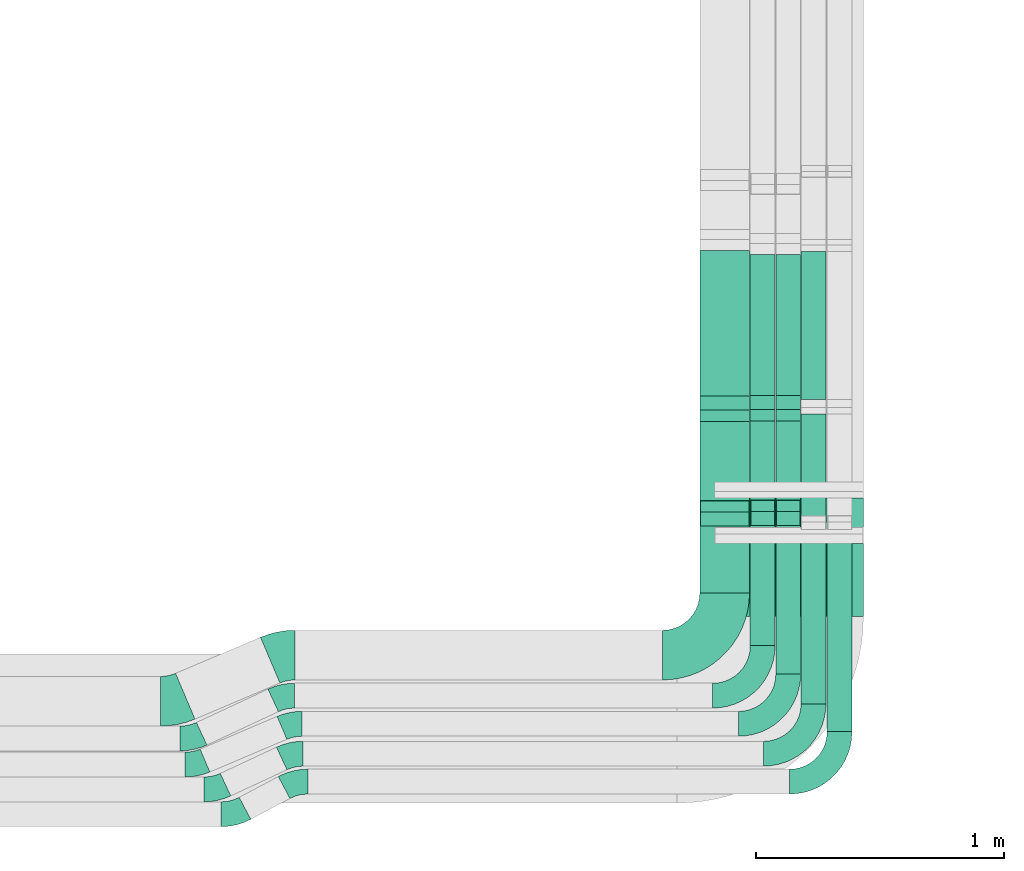
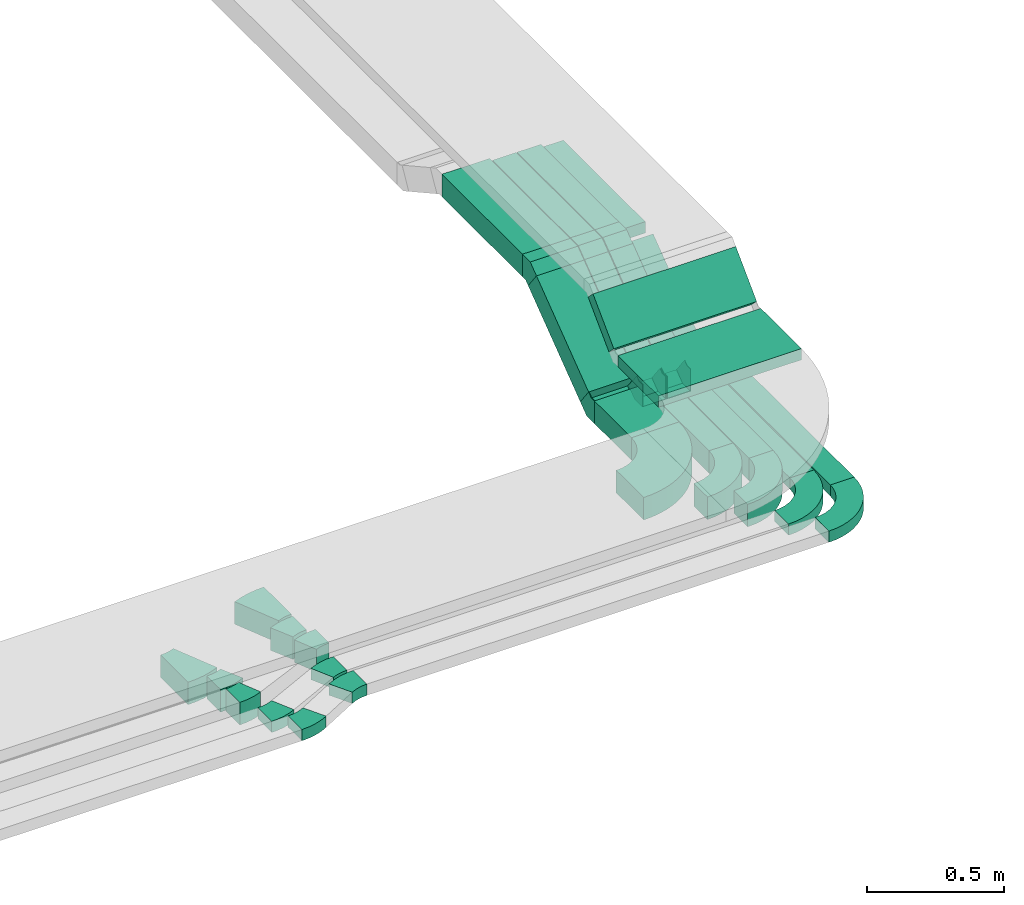
# One storey, part 16 of 28: 21 flow fittings, 15 flow segments.
"""IFC2X3 building model written with IfcOpenShell, lengths in millimetres."""

from ifc_helpers import new_model, entity, si_unit, converted_unit, derived_unit, direction, frame, frame_2d, origin, origin_2d_with_axis, place, context, subcontext, project, spatial, polyline, circle_curve, parameter, trimmed, segment, composite_curve, rectangle, outline, extrude, faceted_brep, source, transform, mapped, material, type_object, type_shapes, element, save


model = new_model("IFC2X3")

# Units and contexts
model_context = context("Model", 3, precision=0.01, world=origin(), true_north=direction((6.12303176911189e-17, 1.0)))
body_context = subcontext(model_context, "Body", "Model", "MODEL_VIEW")
ifc_project = project(units=[si_unit("LENGTHUNIT", "METRE", prefix="MILLI"), si_unit("AREAUNIT", "SQUARE_METRE"), si_unit("VOLUMEUNIT", "CUBIC_METRE"), converted_unit("PLANEANGLEUNIT", "DEGREE", entity("IfcRatioMeasure", 0.0174532925199433), si_unit("PLANEANGLEUNIT", "RADIAN"), dimensions=[0, 0, 0, 0, 0, 0, 0]), si_unit("MASSUNIT", "GRAM", prefix="KILO"), derived_unit("MASSDENSITYUNIT", [(si_unit("MASSUNIT", "GRAM", prefix="KILO"), 1), (si_unit("LENGTHUNIT", "METRE"), -3)]), derived_unit("MOMENTOFINERTIAUNIT", [(si_unit("LENGTHUNIT", "METRE"), 4)]), si_unit("TIMEUNIT", "SECOND"), si_unit("FREQUENCYUNIT", "HERTZ"), si_unit("THERMODYNAMICTEMPERATUREUNIT", "DEGREE_CELSIUS"), derived_unit("THERMALTRANSMITTANCEUNIT", [(si_unit("MASSUNIT", "GRAM", prefix="KILO"), 1), (si_unit("THERMODYNAMICTEMPERATUREUNIT", "KELVIN"), -1), (si_unit("TIMEUNIT", "SECOND"), -3)]), derived_unit("VOLUMETRICFLOWRATEUNIT", [(si_unit("LENGTHUNIT", "METRE"), 3), (si_unit("TIMEUNIT", "SECOND"), -1)]), derived_unit("MASSFLOWRATEUNIT", [(si_unit("MASSUNIT", "GRAM", prefix="KILO"), 1), (si_unit("TIMEUNIT", "SECOND"), -1)]), derived_unit("ROTATIONALFREQUENCYUNIT", [(si_unit("TIMEUNIT", "SECOND"), -1)]), si_unit("ELECTRICCURRENTUNIT", "AMPERE"), si_unit("ELECTRICVOLTAGEUNIT", "VOLT"), si_unit("POWERUNIT", "WATT"), si_unit("FORCEUNIT", "NEWTON", prefix="KILO"), si_unit("ILLUMINANCEUNIT", "LUX"), si_unit("LUMINOUSFLUXUNIT", "LUMEN"), si_unit("LUMINOUSINTENSITYUNIT", "CANDELA"), derived_unit("USERDEFINED", [(si_unit("MASSUNIT", "GRAM", prefix="KILO"), -1), (si_unit("LENGTHUNIT", "METRE"), -2), (si_unit("TIMEUNIT", "SECOND"), 3), (si_unit("LUMINOUSFLUXUNIT", "LUMEN"), 1)]), derived_unit("LINEARVELOCITYUNIT", [(si_unit("LENGTHUNIT", "METRE"), 1), (si_unit("TIMEUNIT", "SECOND"), -1)]), si_unit("PRESSUREUNIT", "PASCAL"), derived_unit("USERDEFINED", [(si_unit("LENGTHUNIT", "METRE"), -2), (si_unit("MASSUNIT", "GRAM", prefix="KILO"), 1), (si_unit("TIMEUNIT", "SECOND"), -2)]), derived_unit("LINEARFORCEUNIT", [(si_unit("MASSUNIT", "GRAM", prefix="KILO"), 1), (si_unit("LENGTHUNIT", "METRE"), 1), (si_unit("TIMEUNIT", "SECOND"), -2), (si_unit("LENGTHUNIT", "METRE"), -1)]), derived_unit("PLANARFORCEUNIT", [(si_unit("MASSUNIT", "GRAM", prefix="KILO"), 1), (si_unit("LENGTHUNIT", "METRE"), 1), (si_unit("TIMEUNIT", "SECOND"), -2), (si_unit("LENGTHUNIT", "METRE"), -2)])], contexts=[model_context])

# Site, building, storey
site_placement = place(None, origin())
site = spatial("IfcSite", under=ifc_project, at=site_placement, CompositionType="ELEMENT")
building_placement = place(site_placement, origin())
building = spatial("IfcBuilding", under=site, at=building_placement, CompositionType="ELEMENT")
storey_placement = place(building_placement, frame((0.0, 0.0, 4200.0)))
storey = spatial("IfcBuildingStorey", under=building, at=storey_placement, CompositionType="ELEMENT", Elevation=4200.0)

# Flow segments
cable_carrier_segment_type = type_object("IfcCableCarrierSegmentType", PredefinedType="CABLETRAYSEGMENT")
flow_segment_1_placement = place(storey_placement, frame((38752.82, 1188.25, 2836.0)))
element("IfcFlowSegment", 1, at=flow_segment_1_placement, inside=storey, type_object=cable_carrier_segment_type, context=body_context, shape_type="SweptSolid", body=[
    extrude(rectangle(XDim=269.298544442396, YDim=199.999999999998, at=origin_2d_with_axis()), frame((100.0, 134.65, 0.0), z_axis=(0.0, 0.0, 1.0), x_axis=(0.0, 1.0, 0.0)), (0.0, 0.0, 1.0), 99.9999999999989),
])
flow_segment_2_placement = place(storey_placement, frame((38752.82, 1499.65, 2870.22)))
element("IfcFlowSegment", 2, at=flow_segment_2_placement, inside=storey, type_object=cable_carrier_segment_type, context=body_context, shape_type="SweptSolid", body=[
    extrude(rectangle(XDim=99.9999999999993, YDim=474.734982904556, at=frame_2d((0.0, 0.0), x_axis=(0.0, 1.0))), frame((0.0, 219.66, 182.78), z_axis=(1.0, 0.0, 0.0), x_axis=(0.0, 0.798635510047289, 0.601815023152054)), (0.0, 0.0, 1.0), 199.999999999998),
])
flow_segment_3_placement = place(storey_placement, frame((38752.82, 1981.06, 3170.01)))
element("IfcFlowSegment", 3, at=flow_segment_3_placement, inside=storey, type_object=cable_carrier_segment_type, context=body_context, shape_type="SweptSolid", body=[
    extrude(rectangle(XDim=585.704970645481, YDim=199.999999999998, at=origin_2d_with_axis()), frame((100.0, 292.85, 0.0), z_axis=(0.0, 0.0, 1.0), x_axis=(0.0, -1.0, 0.0)), (0.0, 0.0, 1.0), 99.9999999999989),
])
flow_segment_4_placement = place(storey_placement, frame((38955.52, 1982.94, 3170.44)))
element("IfcFlowSegment", 4, at=flow_segment_4_placement, inside=storey, type_object=cable_carrier_segment_type, context=body_context, shape_type="SweptSolid", body=[
    extrude(rectangle(XDim=567.712645094914, YDim=100.000000000003, at=origin_2d_with_axis()), frame((50.0, 283.86, 0.0), z_axis=(0.0, 0.0, 1.0), x_axis=(0.0, -1.0, 0.0)), (0.0, 0.0, 1.0), 99.9999999999989),
])
flow_segment_5_placement = place(storey_placement, frame((38955.52, 1500.95, 2870.22)))
element("IfcFlowSegment", 5, at=flow_segment_5_placement, inside=storey, type_object=cable_carrier_segment_type, context=body_context, shape_type="SweptSolid", body=[
    extrude(rectangle(XDim=99.9999999999994, YDim=475.458707317659, at=frame_2d((0.0, 0.0), x_axis=(0.0, 1.0))), frame((0.0, 219.95, 183.0), z_axis=(1.0, 0.0, 0.0), x_axis=(0.0, -0.798635510047221, -0.601815023152144)), (0.0, 0.0, 1.0), 100.000000000003),
])
flow_segment_6_placement = place(storey_placement, frame((38955.52, 975.16, 2836.0)))
element("IfcFlowSegment", 6, at=flow_segment_6_placement, inside=storey, type_object=cable_carrier_segment_type, context=body_context, shape_type="SweptSolid", body=[
    extrude(rectangle(XDim=483.697987779562, YDim=100.000000000003, at=origin_2d_with_axis()), frame((50.0, 241.85, 0.0), z_axis=(0.0, 0.0, 1.0), x_axis=(0.0, 1.0, 0.0)), (0.0, 0.0, 1.0), 100.0),
])
flow_segment_7_placement = place(storey_placement, frame((39058.82, 861.76, 2836.0)))
element("IfcFlowSegment", 7, at=flow_segment_7_placement, inside=storey, type_object=cable_carrier_segment_type, context=body_context, shape_type="SweptSolid", body=[
    extrude(rectangle(XDim=597.090583745162, YDim=99.9999999999946, at=origin_2d_with_axis()), frame((50.0, 298.55, 0.0), z_axis=(0.0, 0.0, 1.0), x_axis=(0.0, 1.0, 0.0)), (0.0, 0.0, 1.0), 99.9999999999989),
])
flow_segment_8_placement = place(storey_placement, frame((39058.82, 1982.94, 3170.44)))
element("IfcFlowSegment", 8, at=flow_segment_8_placement, inside=storey, type_object=cable_carrier_segment_type, context=body_context, shape_type="SweptSolid", body=[
    extrude(rectangle(XDim=567.712645094897, YDim=99.9999999999946, at=origin_2d_with_axis()), frame((50.0, 283.86, 0.0), z_axis=(0.0, 0.0, 1.0), x_axis=(0.0, -1.0, 0.0)), (0.0, 0.0, 1.0), 99.9999999999989),
])
flow_segment_9_placement = place(storey_placement, frame((39058.82, 1500.95, 2870.22)))
element("IfcFlowSegment", 9, at=flow_segment_9_placement, inside=storey, type_object=cable_carrier_segment_type, context=body_context, shape_type="SweptSolid", body=[
    extrude(rectangle(XDim=100.000000000001, YDim=99.9999999999946, at=origin_2d_with_axis()), frame((50.0, 30.09, 39.93), z_axis=(0.0, 0.798635510047284, 0.60181502315206), x_axis=(0.0, -0.60181502315206, 0.798635510047284)), (0.0, 0.0, 1.0), 475.45870731771),
])
flow_segment_10_placement = place(storey_placement, frame((39265.32, 629.11, 2836.0)))
element("IfcFlowSegment", 10, at=flow_segment_10_placement, inside=storey, type_object=cable_carrier_segment_type, context=body_context, shape_type="SweptSolid", body=[
    extrude(rectangle(XDim=813.299265565232, YDim=99.9999999999946, at=origin_2d_with_axis()), frame((50.0, 406.65, 0.0), z_axis=(0.0, 0.0, 1.0), x_axis=(0.0, 1.0, 0.0)), (0.0, 0.0, 1.0), 49.9999999999995),
])
flow_segment_11_placement = place(storey_placement, frame((39160.32, 1966.21, 3195.44)))
element("IfcFlowSegment", 11, at=flow_segment_11_placement, inside=storey, type_object=cable_carrier_segment_type, context=body_context, shape_type="SweptSolid", body=[
    extrude(rectangle(XDim=597.373290287799, YDim=99.9999999999946, at=origin_2d_with_axis()), frame((50.0, 298.69, 0.0), z_axis=(0.0, 0.0, 1.0), x_axis=(0.0, -1.0, 0.0)), (0.0, 0.0, 1.0), 49.9999999999995),
])
flow_segment_12_placement = place(storey_placement, frame((39160.32, 1469.46, 2855.12)))
element("IfcFlowSegment", 12, at=flow_segment_12_placement, inside=storey, type_object=cable_carrier_segment_type, context=body_context, shape_type="SweptSolid", body=[
    extrude(rectangle(XDim=49.9999999999999, YDim=550.459242796006, at=frame_2d((0.0, 0.0), x_axis=(0.0, 1.0))), frame((0.0, 234.85, 185.6), z_axis=(1.0, 0.0, 0.0), x_axis=(0.0, -0.798635510047261, -0.60181502315209)), (0.0, 0.0, 1.0), 99.9999999999945),
])
flow_segment_13_placement = place(storey_placement, frame((39160.32, 741.35, 2836.0)))
element("IfcFlowSegment", 13, at=flow_segment_13_placement, inside=storey, type_object=cable_carrier_segment_type, context=body_context, shape_type="SweptSolid", body=[
    extrude(rectangle(XDim=701.061094153478, YDim=99.9999999999946, at=origin_2d_with_axis()), frame((50.0, 350.53, 0.0), z_axis=(0.0, 0.0, 1.0), x_axis=(0.0, 1.0, 0.0)), (0.0, 0.0, 1.0), 49.9999999999995),
])
flow_segment_14_placement = place(storey_placement, frame((38811.38, 1417.48, 3135.82)))
element("IfcFlowSegment", 14, at=flow_segment_14_placement, inside=storey, type_object=cable_carrier_segment_type, context=body_context, shape_type="SweptSolid", body=[
    extrude(rectangle(XDim=49.9999999999995, YDim=214.759813245738, at=frame_2d((0.0, 0.0), x_axis=(0.0, 1.0))), frame((0.0, 93.61, 93.61), z_axis=(1.0, 0.0, 0.0), x_axis=(0.0, -0.707106781186602, -0.707106781186493)), (0.0, 0.0, 1.0), 600.000000000002),
])
flow_segment_15_placement = place(storey_placement, frame((38811.38, 1092.66, 3108.85)))
element("IfcFlowSegment", 15, at=flow_segment_15_placement, inside=storey, type_object=cable_carrier_segment_type, context=body_context, shape_type="SweptSolid", body=[
    extrude(rectangle(XDim=295.070811915794, YDim=600.000000000002, at=origin_2d_with_axis()), frame((300.0, 147.54, 0.0), z_axis=(0.0, 0.0, 1.0), x_axis=(0.0, 1.0, 0.0)), (0.0, 0.0, 1.0), 49.9999999999995),
])

# Flow fittings
ifc_material = material()
cable_carrier_fitting_type_1 = type_object("IfcCableCarrierFittingType", PredefinedType="NOTDEFINED", material=ifc_material)
shared_shape_1 = source(origin(), body_context, "Body", "Brep", [
    faceted_brep([(-40.13, -50.0, 100.0), (-40.13, 50.0, 100.0), (-40.13, 50.0, 97.46), (-40.13, -47.46, 97.46), (-40.13, -47.46, -97.46), (-40.13, 50.0, -97.46), (-40.13, 50.0, -100.0), (-40.13, -50.0, -100.0), (62.14, -15.78, 100.0), (62.14, -15.78, -100.0), (1.96, 64.08, -100.0), (1.96, 64.08, -97.46), (60.61, -13.75, -97.46), (60.61, -13.75, 97.46), (1.96, 64.08, 97.46), (1.96, 64.08, 100.0), (16.73, -50.0, 100.0), (-16.73, 50.0, 100.0), (-16.73, 50.0, 97.46), (15.88, -47.46, 97.46), (15.88, -47.46, -97.46), (-16.73, 50.0, -97.46), (-16.73, 50.0, -100.0), (16.73, -50.0, -100.0)], [[[0, 1, 2, 3, 4, 5, 6, 7]], [[8, 9, 10, 11, 12, 13, 14, 15]], [[1, 0, 16, 8, 15, 17]], [[2, 1, 17, 18]], [[3, 2, 18, 14, 13, 19]], [[4, 3, 19, 20]], [[5, 4, 20, 12, 11, 21]], [[6, 5, 21, 22]], [[7, 6, 22, 10, 9, 23]], [[0, 7, 23, 16]], [[18, 17, 15, 14]], [[20, 19, 13, 12]], [[22, 21, 11, 10]], [[16, 23, 9, 8]]]),
])
type_shapes(cable_carrier_fitting_type_1, [shared_shape_1])
for number, where, z_axis, x_axis in (
    (16, (38852.82, 1497.69, 2886.0), (1.0, 0.0, 0.0), (0.0, 1.0, 0.0)),
    (17, (38852.82, 1940.93, 3220.01), (-1.0, 0.0, 0.0), (0.0, 0.798635510047237, 0.601815023152122)),
):
    element("IfcFlowFitting", number, at=place(storey_placement, frame(where, z_axis=z_axis, x_axis=x_axis)), inside=storey, type_object=cable_carrier_fitting_type_1, material=ifc_material, context=body_context, shape_type="MappedRepresentation", body=[
        mapped(shared_shape_1, transform((0.0, 0.0, 0.0), scale=1.0)),
    ])
cable_carrier_fitting_type_2 = type_object("IfcCableCarrierFittingType", PredefinedType="NOTDEFINED", material=ifc_material)
shared_shape_2 = source(origin(), body_context, "Body", "Brep", [
    faceted_brep([(-40.13, -50.0, 50.0), (-40.13, 50.0, 50.0), (-40.13, 50.0, 47.46), (-40.13, -47.46, 47.46), (-40.13, -47.46, -47.46), (-40.13, 50.0, -47.46), (-40.13, 50.0, -50.0), (-40.13, -50.0, -50.0), (62.14, -15.78, 50.0), (62.14, -15.78, -50.0), (1.96, 64.08, -50.0), (1.96, 64.08, -47.46), (60.61, -13.75, -47.46), (60.61, -13.75, 47.46), (1.96, 64.08, 47.46), (1.96, 64.08, 50.0), (16.73, -50.0, 50.0), (-16.73, 50.0, 50.0), (-16.73, 50.0, 47.46), (15.88, -47.46, 47.46), (15.88, -47.46, -47.46), (-16.73, 50.0, -47.46), (-16.73, 50.0, -50.0), (16.73, -50.0, -50.0)], [[[0, 1, 2, 3, 4, 5, 6, 7]], [[8, 9, 10, 11, 12, 13, 14, 15]], [[1, 0, 16, 8, 15, 17]], [[2, 1, 17, 18]], [[3, 2, 18, 14, 13, 19]], [[4, 3, 19, 20]], [[5, 4, 20, 12, 11, 21]], [[6, 5, 21, 22]], [[7, 6, 22, 10, 9, 23]], [[0, 7, 23, 16]], [[18, 17, 15, 14]], [[20, 19, 13, 12]], [[22, 21, 11, 10]], [[16, 23, 9, 8]]]),
])
type_shapes(cable_carrier_fitting_type_2, [shared_shape_2])
for number, where, z_axis, x_axis in (
    (18, (39005.52, 1942.81, 3220.44), (1.0, 0.0, 0.0), (0.0, -1.0, 0.0)),
    (19, (39005.52, 1498.99, 2886.0), (1.0, 0.0, 0.0), (0.0, 1.0, 0.0)),
    (20, (39108.82, 1942.81, 3220.44), (1.0, 0.0, 0.0), (0.0, -1.0, 0.0)),
    (21, (39108.82, 1498.99, 2886.0), (-1.0, 0.0, 0.0), (0.0, -0.79863551004726, -0.601815023152092)),
):
    element("IfcFlowFitting", number, at=place(storey_placement, frame(where, z_axis=z_axis, x_axis=x_axis)), inside=storey, type_object=cable_carrier_fitting_type_2, material=ifc_material, context=body_context, shape_type="MappedRepresentation", body=[
        mapped(shared_shape_2, transform((0.0, 0.0, 0.0), scale=1.0)),
    ])
cable_carrier_fitting_type_3 = type_object("IfcCableCarrierFittingType", Name="470_DKC_S5_Variable Angle Elbow 0-45:-", PredefinedType="NOTDEFINED", material=ifc_material)
shared_shape_3 = source(origin(), body_context, "Body", "SweptSolid", [
    extrude(outline(composite_curve([segment(polyline([(-125.75, -225.25), (-124.75, -225.25)]), True, "CONTINUOUS"), segment(trimmed(circle_curve(frame_2d((-124.75, 124.75), x_axis=(0.0, -1.0)), 350.0), [parameter(0.0)], [parameter(90.0000000000001)], True, "PARAMETER"), True, "CONTINUOUS"), segment(polyline([(225.25, 124.75), (225.25, 125.75)]), True, "CONTINUOUS"), segment(polyline([(225.25, 125.75), (25.25, 125.75)]), True, "CONTINUOUS"), segment(polyline([(25.25, 125.75), (25.25, 124.75)]), True, "CONTINUOUS"), segment(trimmed(circle_curve(frame_2d((-124.75, 124.75), x_axis=(0.0, -1.0)), 150.0), [parameter(0.0)], [parameter(90.0000000000001)], True, "PARAMETER"), False, "CONTINUOUS"), segment(polyline([(-124.75, -25.25), (-125.75, -25.25)]), True, "CONTINUOUS"), segment(polyline([(-125.75, -25.25), (-125.75, -225.25)]), True, "CONTINUOUS")], self_intersect=False)), frame((-125.25, 125.25, -50.0)), (0.0, 0.0, 1.0), 100.0),
])
type_shapes(cable_carrier_fitting_type_3, [shared_shape_3])
flow_fitting_1_placement = place(storey_placement, frame((38852.82, 937.25, 2886.0)))
element("IfcFlowFitting", 22, at=flow_fitting_1_placement, inside=storey, type_object=cable_carrier_fitting_type_3, material=ifc_material, Name="470_DKC_S5_Variable Angle Elbow 0-45:-", ObjectType="470_DKC_S5_Variable Angle Elbow 0-45:-", context=body_context, shape_type="MappedRepresentation", body=[
    mapped(shared_shape_3, transform((0.0, 0.0, 0.0), scale=1.0)),
])
cable_carrier_fitting_type_4 = type_object("IfcCableCarrierFittingType", Name="470_DKC_S5_Variable Angle Elbow 0-45:-", PredefinedType="NOTDEFINED", material=ifc_material)
shared_shape_4 = source(origin(), body_context, "Body", "SweptSolid", [
    extrude(outline(composite_curve([segment(polyline([(-100.75, -150.25), (-99.75, -150.25)]), True, "CONTINUOUS"), segment(trimmed(circle_curve(frame_2d((-99.75, 99.75), x_axis=(0.0, -1.0)), 250.0), [parameter(0.0)], [parameter(90.0000000000001)], True, "PARAMETER"), True, "CONTINUOUS"), segment(polyline([(150.25, 99.75), (150.25, 100.75)]), True, "CONTINUOUS"), segment(polyline([(150.25, 100.75), (50.25, 100.75)]), True, "CONTINUOUS"), segment(polyline([(50.25, 100.75), (50.25, 99.75)]), True, "CONTINUOUS"), segment(trimmed(circle_curve(frame_2d((-99.75, 99.75), x_axis=(0.0, -1.0)), 150.0), [parameter(0.0)], [parameter(90.0000000000001)], True, "PARAMETER"), False, "CONTINUOUS"), segment(polyline([(-99.75, -50.25), (-100.75, -50.25)]), True, "CONTINUOUS"), segment(polyline([(-100.75, -50.25), (-100.75, -150.25)]), True, "CONTINUOUS")], self_intersect=False)), frame((-100.25, 100.25, -25.0)), (0.0, 0.0, 1.0), 49.9999999999997),
])
type_shapes(cable_carrier_fitting_type_4, [shared_shape_4])
for number, where, name in (
    (23, (39210.32, 540.35, 2861.0), "470_DKC_S5_Variable Angle Elbow 0-45:-"),
    (24, (39315.32, 428.11, 2861.0), "470_DKC_S5_Variable Angle Elbow 0-45:-"),
):
    element("IfcFlowFitting", number, at=place(storey_placement, frame(where)), inside=storey, type_object=cable_carrier_fitting_type_4, material=ifc_material, Name=name, ObjectType="470_DKC_S5_Variable Angle Elbow 0-45:-", context=body_context, shape_type="MappedRepresentation", body=[
        mapped(shared_shape_4, transform((0.0, 0.0, 0.0), scale=1.0)),
    ])
cable_carrier_fitting_type_5 = type_object("IfcCableCarrierFittingType", Name="470_DKC_S5_Variable Angle Elbow 0-45:-", PredefinedType="NOTDEFINED", material=ifc_material)
shared_shape_5 = source(origin(), body_context, "Body", "SweptSolid", [
    extrude(outline(composite_curve([segment(polyline([(-100.75, -150.25), (-99.75, -150.25)]), True, "CONTINUOUS"), segment(trimmed(circle_curve(frame_2d((-99.75, 99.75), x_axis=(0.0, -1.0)), 250.0), [parameter(0.0)], [parameter(90.0000000000001)], True, "PARAMETER"), True, "CONTINUOUS"), segment(polyline([(150.25, 99.75), (150.25, 100.75)]), True, "CONTINUOUS"), segment(polyline([(150.25, 100.75), (50.25, 100.75)]), True, "CONTINUOUS"), segment(polyline([(50.25, 100.75), (50.25, 99.75)]), True, "CONTINUOUS"), segment(trimmed(circle_curve(frame_2d((-99.75, 99.75), x_axis=(0.0, -1.0)), 150.0), [parameter(0.0)], [parameter(90.0000000000001)], True, "PARAMETER"), False, "CONTINUOUS"), segment(polyline([(-99.75, -50.25), (-100.75, -50.25)]), True, "CONTINUOUS"), segment(polyline([(-100.75, -50.25), (-100.75, -150.25)]), True, "CONTINUOUS")], self_intersect=False)), frame((-100.25, 100.25, -50.0)), (0.0, 0.0, 1.0), 100.0),
])
type_shapes(cable_carrier_fitting_type_5, [shared_shape_5])
for number, where, name in (
    (25, (39005.52, 774.16, 2886.0), "470_DKC_S5_Variable Angle Elbow 0-45:-"),
    (26, (39108.82, 660.76, 2886.0), "470_DKC_S5_Variable Angle Elbow 0-45:-"),
):
    element("IfcFlowFitting", number, at=place(storey_placement, frame(where)), inside=storey, type_object=cable_carrier_fitting_type_5, material=ifc_material, Name=name, ObjectType="470_DKC_S5_Variable Angle Elbow 0-45:-", context=body_context, shape_type="MappedRepresentation", body=[
        mapped(shared_shape_5, transform((0.0, 0.0, 0.0), scale=1.0)),
    ])
cable_carrier_fitting_type_6 = type_object("IfcCableCarrierFittingType", Name="470_DKC_S5_Variable Angle Elbow 0-45:-", PredefinedType="NOTDEFINED", material=ifc_material)
shared_shape_6 = source(origin(), body_context, "Body", "SweptSolid", [
    extrude(outline(composite_curve([segment(polyline([(-43.24, -59.47), (-42.24, -59.47)]), True, "CONTINUOUS"), segment(trimmed(circle_curve(frame_2d((-42.24, 190.53), x_axis=(0.0, -1.0)), 250.0), [parameter(0.0)], [parameter(24.9999999999996)], True, "PARAMETER"), True, "CONTINUOUS"), segment(polyline([(63.42, -36.05), (64.32, -35.63)]), True, "CONTINUOUS"), segment(polyline([(64.32, -35.63), (22.06, 55.0)]), True, "CONTINUOUS"), segment(polyline([(22.06, 55.0), (21.15, 54.58)]), True, "CONTINUOUS"), segment(trimmed(circle_curve(frame_2d((-42.24, 190.53), x_axis=(0.0, -1.0)), 150.0), [parameter(0.0)], [parameter(24.9999999999996)], True, "PARAMETER"), False, "CONTINUOUS"), segment(polyline([(-42.24, 40.53), (-43.24, 40.53)]), True, "CONTINUOUS"), segment(polyline([(-43.24, 40.53), (-43.24, -59.47)]), True, "CONTINUOUS")], self_intersect=False)), frame((-2.1, 9.47, -25.0)), (0.0, 0.0, 1.0), 50.0),
])
type_shapes(cable_carrier_fitting_type_6, [shared_shape_6])
flow_fitting_2_placement = place(storey_placement, frame((36801.82, 396.66, 2861.0)))
element("IfcFlowFitting", 27, at=flow_fitting_2_placement, inside=storey, type_object=cable_carrier_fitting_type_6, material=ifc_material, Name="470_DKC_S5_Variable Angle Elbow 0-45:-", ObjectType="470_DKC_S5_Variable Angle Elbow 0-45:-", context=body_context, shape_type="MappedRepresentation", body=[
    mapped(shared_shape_6, transform((0.0, 0.0, 0.0), scale=1.0)),
])
flow_fitting_3_placement = place(storey_placement, frame((37109.97, 540.35, 2861.0), z_axis=(0.0, 0.0, 1.0), x_axis=(-1.0, 0.0, 0.0)))
element("IfcFlowFitting", 28, at=flow_fitting_3_placement, inside=storey, type_object=cable_carrier_fitting_type_6, material=ifc_material, Name="470_DKC_S5_Variable Angle Elbow 0-45:-", ObjectType="470_DKC_S5_Variable Angle Elbow 0-45:-", context=body_context, shape_type="MappedRepresentation", body=[
    mapped(shared_shape_6, transform((0.0, 0.0, 0.0), scale=1.0)),
])
cable_carrier_fitting_type_7 = type_object("IfcCableCarrierFittingType", Name="470_DKC_S5_Variable Angle Elbow 0-45:-", PredefinedType="NOTDEFINED", material=ifc_material)
shared_shape_7 = source(origin(), body_context, "Body", "SweptSolid", [
    extrude(outline(composite_curve([segment(polyline([(-47.92, -61.82), (-46.92, -61.82)]), True, "CONTINUOUS"), segment(trimmed(circle_curve(frame_2d((-46.92, 188.18), x_axis=(0.0, -1.0)), 250.0), [parameter(0.0)], [parameter(27.9999999999998)], True, "PARAMETER"), True, "CONTINUOUS"), segment(polyline([(70.45, -32.56), (71.33, -32.09)]), True, "CONTINUOUS"), segment(polyline([(71.33, -32.09), (24.39, 56.2)]), True, "CONTINUOUS"), segment(polyline([(24.39, 56.2), (23.5, 55.74)]), True, "CONTINUOUS"), segment(trimmed(circle_curve(frame_2d((-46.92, 188.18), x_axis=(0.0, -1.0)), 150.0), [parameter(0.0)], [parameter(27.9999999999998)], True, "PARAMETER"), False, "CONTINUOUS"), segment(polyline([(-46.92, 38.18), (-47.92, 38.18)]), True, "CONTINUOUS"), segment(polyline([(-47.92, 38.18), (-47.92, -61.82)]), True, "CONTINUOUS")], self_intersect=False)), frame((-2.95, 11.82, -25.0)), (0.0, 0.0, 1.0), 50.0),
])
type_shapes(cable_carrier_fitting_type_7, [shared_shape_7])
flow_fitting_4_placement = place(storey_placement, frame((36876.32, 296.66, 2861.0)))
element("IfcFlowFitting", 29, at=flow_fitting_4_placement, inside=storey, type_object=cable_carrier_fitting_type_7, material=ifc_material, Name="470_DKC_S5_Variable Angle Elbow 0-45:-", ObjectType="470_DKC_S5_Variable Angle Elbow 0-45:-", context=body_context, shape_type="MappedRepresentation", body=[
    mapped(shared_shape_7, transform((0.0, 0.0, 0.0), scale=1.0)),
])
flow_fitting_5_placement = place(storey_placement, frame((37123.54, 428.11, 2861.0), z_axis=(0.0, 0.0, 1.0), x_axis=(-1.0, 0.0, 0.0)))
element("IfcFlowFitting", 30, at=flow_fitting_5_placement, inside=storey, type_object=cable_carrier_fitting_type_7, material=ifc_material, Name="470_DKC_S5_Variable Angle Elbow 0-45:-", ObjectType="470_DKC_S5_Variable Angle Elbow 0-45:-", context=body_context, shape_type="MappedRepresentation", body=[
    mapped(shared_shape_7, transform((0.0, 0.0, 0.0), scale=1.0)),
])
cable_carrier_fitting_type_8 = type_object("IfcCableCarrierFittingType", Name="470_DKC_S5_Variable Angle Elbow 0-45:-", PredefinedType="NOTDEFINED", material=ifc_material)
shared_shape_8 = source(origin(), body_context, "Body", "SweptSolid", [
    extrude(outline(composite_curve([segment(polyline([(-40.05, -58.05), (-39.05, -58.05)]), True, "CONTINUOUS"), segment(trimmed(circle_curve(frame_2d((-39.05, 191.95), x_axis=(0.0, -1.0)), 250.0), [parameter(0.0)], [parameter(23.0)], True, "PARAMETER"), True, "CONTINUOUS"), segment(polyline([(58.63, -38.17), (59.55, -37.78)]), True, "CONTINUOUS"), segment(polyline([(59.55, -37.78), (20.48, 54.27)]), True, "CONTINUOUS"), segment(polyline([(20.48, 54.27), (19.56, 53.88)]), True, "CONTINUOUS"), segment(trimmed(circle_curve(frame_2d((-39.05, 191.95), x_axis=(0.0, -1.0)), 150.0), [parameter(0.0)], [parameter(23.0)], True, "PARAMETER"), False, "CONTINUOUS"), segment(polyline([(-39.05, 41.95), (-40.05, 41.95)]), True, "CONTINUOUS"), segment(polyline([(-40.05, 41.95), (-40.05, -58.05)]), True, "CONTINUOUS")], self_intersect=False)), frame((-1.64, 8.05, -50.0)), (0.0, 0.0, 1.0), 100.0),
])
type_shapes(cable_carrier_fitting_type_8, [shared_shape_8])
flow_fitting_6_placement = place(storey_placement, frame((36721.82, 496.66, 2886.0)))
element("IfcFlowFitting", 31, at=flow_fitting_6_placement, inside=storey, type_object=cable_carrier_fitting_type_8, material=ifc_material, Name="470_DKC_S5_Variable Angle Elbow 0-45:-", ObjectType="470_DKC_S5_Variable Angle Elbow 0-45:-", context=body_context, shape_type="MappedRepresentation", body=[
    mapped(shared_shape_8, transform((0.0, 0.0, 0.0), scale=1.0)),
])
flow_fitting_7_placement = place(storey_placement, frame((37108.43, 660.76, 2886.0), z_axis=(0.0, 0.0, 1.0), x_axis=(-1.0, 0.0, 0.0)))
element("IfcFlowFitting", 32, at=flow_fitting_7_placement, inside=storey, type_object=cable_carrier_fitting_type_8, material=ifc_material, Name="470_DKC_S5_Variable Angle Elbow 0-45:-", ObjectType="470_DKC_S5_Variable Angle Elbow 0-45:-", context=body_context, shape_type="MappedRepresentation", body=[
    mapped(shared_shape_8, transform((0.0, 0.0, 0.0), scale=1.0)),
])
cable_carrier_fitting_type_9 = type_object("IfcCableCarrierFittingType", Name="470_DKC_S5_Variable Angle Elbow 0-45:-", PredefinedType="NOTDEFINED", material=ifc_material)
shared_shape_9 = source(origin(), body_context, "Body", "SweptSolid", [
    extrude(outline(composite_curve([segment(polyline([(-43.24, -59.47), (-42.24, -59.47)]), True, "CONTINUOUS"), segment(trimmed(circle_curve(frame_2d((-42.24, 190.53), x_axis=(0.0, -1.0)), 250.0), [parameter(0.0)], [parameter(25.0000000000054)], True, "PARAMETER"), True, "CONTINUOUS"), segment(polyline([(63.42, -36.05), (64.32, -35.63)]), True, "CONTINUOUS"), segment(polyline([(64.32, -35.63), (22.06, 55.0)]), True, "CONTINUOUS"), segment(polyline([(22.06, 55.0), (21.15, 54.58)]), True, "CONTINUOUS"), segment(trimmed(circle_curve(frame_2d((-42.24, 190.53), x_axis=(0.0, -1.0)), 150.0), [parameter(0.0)], [parameter(25.0000000000054)], True, "PARAMETER"), False, "CONTINUOUS"), segment(polyline([(-42.24, 40.53), (-43.24, 40.53)]), True, "CONTINUOUS"), segment(polyline([(-43.24, 40.53), (-43.24, -59.47)]), True, "CONTINUOUS")], self_intersect=False)), frame((-2.1, 9.47, -50.0)), (0.0, 0.0, 1.0), 100.0),
])
type_shapes(cable_carrier_fitting_type_9, [shared_shape_9])
flow_fitting_8_placement = place(storey_placement, frame((36705.74, 601.66, 2886.0)))
element("IfcFlowFitting", 33, at=flow_fitting_8_placement, inside=storey, type_object=cable_carrier_fitting_type_9, material=ifc_material, Name="470_DKC_S5_Variable Angle Elbow 0-45:-", ObjectType="470_DKC_S5_Variable Angle Elbow 0-45:-", context=body_context, shape_type="MappedRepresentation", body=[
    mapped(shared_shape_9, transform((0.0, 0.0, 0.0), scale=1.0)),
])
flow_fitting_9_placement = place(storey_placement, frame((37075.67, 774.16, 2886.0), z_axis=(0.0, 0.0, 1.0), x_axis=(-1.0, 0.0, 0.0)))
element("IfcFlowFitting", 34, at=flow_fitting_9_placement, inside=storey, type_object=cable_carrier_fitting_type_9, material=ifc_material, Name="470_DKC_S5_Variable Angle Elbow 0-45:-", ObjectType="470_DKC_S5_Variable Angle Elbow 0-45:-", context=body_context, shape_type="MappedRepresentation", body=[
    mapped(shared_shape_9, transform((0.0, 0.0, 0.0), scale=1.0)),
])
cable_carrier_fitting_type_10 = type_object("IfcCableCarrierFittingType", Name="470_DKC_S5_Variable Angle Elbow 0-45:-", PredefinedType="NOTDEFINED", material=ifc_material)
shared_shape_10 = source(origin(), body_context, "Body", "SweptSolid", [
    extrude(outline(composite_curve([segment(polyline([(-49.82, -110.03), (-48.82, -110.03)]), True, "CONTINUOUS"), segment(trimmed(circle_curve(frame_2d((-48.82, 239.97), x_axis=(0.0, -1.0)), 350.0), [parameter(0.0)], [parameter(23.000000000004)], True, "PARAMETER"), True, "CONTINUOUS"), segment(polyline([(87.93, -82.21), (88.85, -81.82)]), True, "CONTINUOUS"), segment(polyline([(88.85, -81.82), (10.71, 102.28)]), True, "CONTINUOUS"), segment(polyline([(10.71, 102.28), (9.79, 101.89)]), True, "CONTINUOUS"), segment(trimmed(circle_curve(frame_2d((-48.82, 239.97), x_axis=(0.0, -1.0)), 150.0), [parameter(0.0)], [parameter(23.000000000004)], True, "PARAMETER"), False, "CONTINUOUS"), segment(polyline([(-48.82, 89.97), (-49.82, 89.97)]), True, "CONTINUOUS"), segment(polyline([(-49.82, 89.97), (-49.82, -110.03)]), True, "CONTINUOUS")], self_intersect=False)), frame((-2.04, 10.03, -50.0)), (0.0, 0.0, 1.0), 100.0),
])
type_shapes(cable_carrier_fitting_type_10, [shared_shape_10])
flow_fitting_10_placement = place(storey_placement, frame((36633.09, 751.66, 2886.0)))
element("IfcFlowFitting", 35, at=flow_fitting_10_placement, inside=storey, type_object=cable_carrier_fitting_type_10, material=ifc_material, Name="470_DKC_S5_Variable Angle Elbow 0-45:-", ObjectType="470_DKC_S5_Variable Angle Elbow 0-45:-", context=body_context, shape_type="MappedRepresentation", body=[
    mapped(shared_shape_10, transform((0.0, 0.0, 0.0), scale=1.0)),
])
flow_fitting_11_placement = place(storey_placement, frame((37070.33, 937.25, 2886.0), z_axis=(0.0, 0.0, 1.0), x_axis=(-1.0, 0.0, 0.0)))
element("IfcFlowFitting", 36, at=flow_fitting_11_placement, inside=storey, type_object=cable_carrier_fitting_type_10, material=ifc_material, Name="470_DKC_S5_Variable Angle Elbow 0-45:-", ObjectType="470_DKC_S5_Variable Angle Elbow 0-45:-", context=body_context, shape_type="MappedRepresentation", body=[
    mapped(shared_shape_10, transform((0.0, 0.0, 0.0), scale=1.0)),
])

save(model, "model.ifc")
